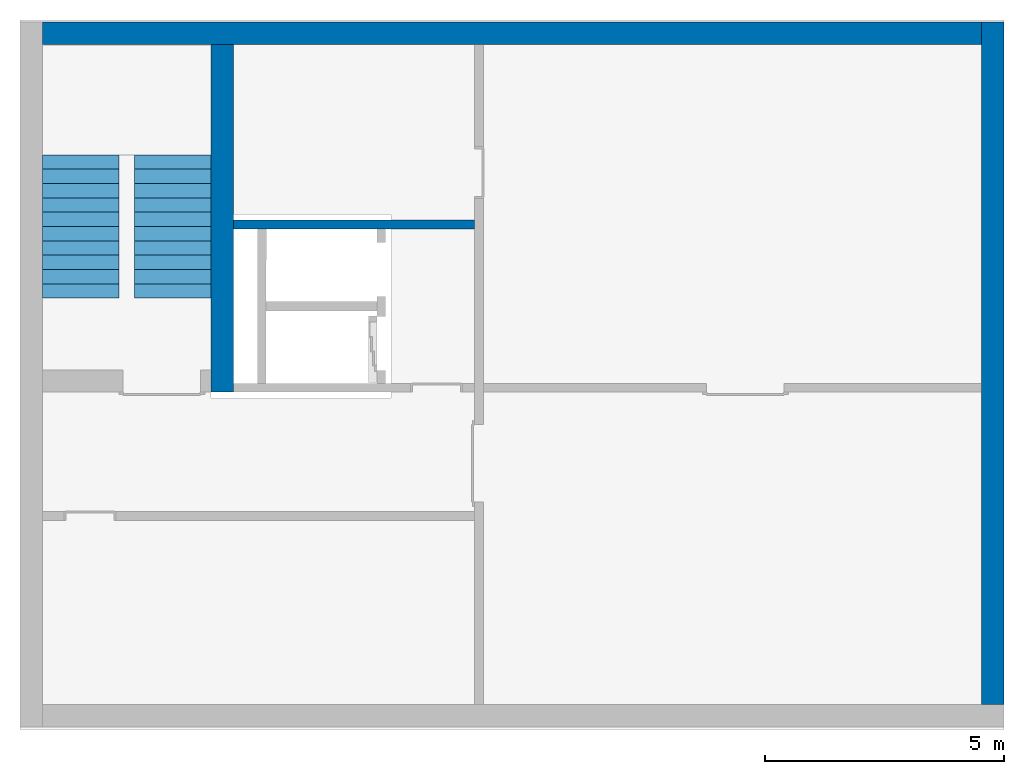
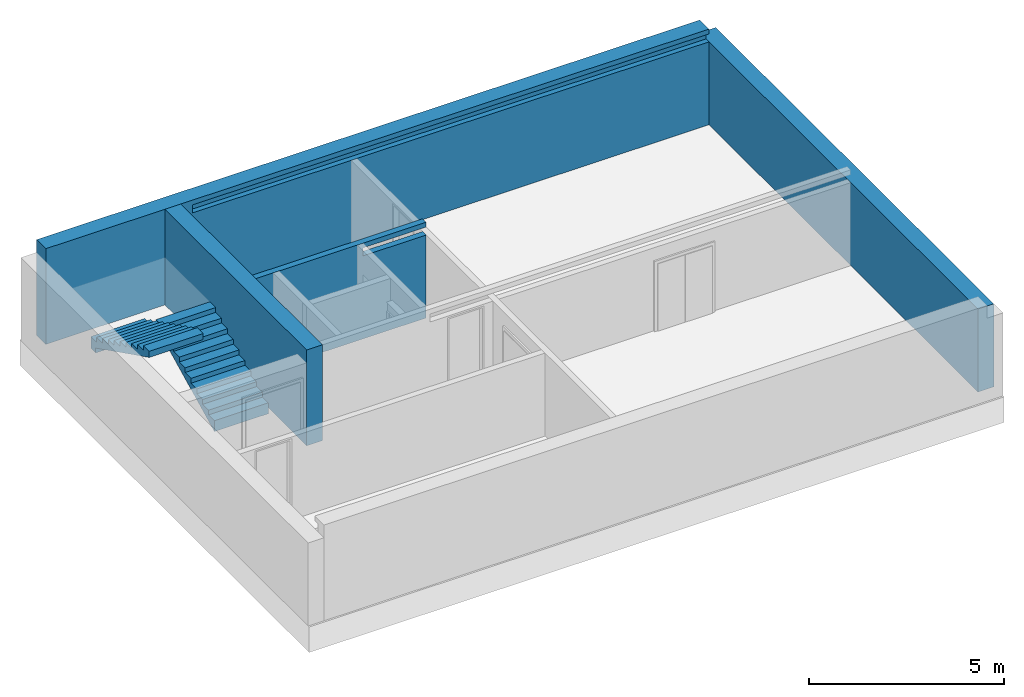
# One storey, part 2 of 3: 4 walls, 2 building element parts, 2 elements without a shape of their own.
"""IFC4 building model written with IfcOpenShell, lengths in metres."""

from ifc_helpers import new_model, entity, si_unit, converted_unit, derived_unit, direction, frame, origin_with_axes, place, context, subcontext, project, spatial, polygons, material, type_object, element, aggregate, save


model = new_model("IFC4")

# Units and contexts
model_context = context("Model", 3, precision=1e-05, world=origin_with_axes(), true_north=direction((0.0, 1.0)))
body_context = subcontext(model_context, "Body", "Model", "MODEL_VIEW")
ifc_project = project(units=[si_unit("LENGTHUNIT", "METRE"), si_unit("AREAUNIT", "SQUARE_METRE"), si_unit("VOLUMEUNIT", "CUBIC_METRE"), converted_unit("PLANEANGLEUNIT", "DEGREE", entity("IfcPlaneAngleMeasure", 0.0174532925199433), si_unit("PLANEANGLEUNIT", "RADIAN"), dimensions=[0, 0, 0, 0, 0, 0, 0]), converted_unit("TIMEUNIT", "Year", entity("IfcTimeMeasure", 31557600.0), si_unit("TIMEUNIT", "SECOND"), dimensions=[0, 0, 1, 0, 0, 0, 0]), si_unit("MASSUNIT", "GRAM", prefix="KILO"), si_unit("THERMODYNAMICTEMPERATUREUNIT", "DEGREE_CELSIUS"), si_unit("LUMINOUSINTENSITYUNIT", "LUMEN"), si_unit("ENERGYUNIT", "JOULE", prefix="MEGA"), derived_unit("THERMALCONDUCTANCEUNIT", [(si_unit("POWERUNIT", "WATT"), 1), (si_unit("LENGTHUNIT", "METRE"), -1), (si_unit("THERMODYNAMICTEMPERATUREUNIT", "KELVIN"), -1)]), derived_unit("SPECIFICHEATCAPACITYUNIT", [(si_unit("ENERGYUNIT", "JOULE"), 1), (si_unit("MASSUNIT", "GRAM", prefix="KILO"), -1), (si_unit("THERMODYNAMICTEMPERATUREUNIT", "KELVIN"), -1)]), derived_unit("MASSDENSITYUNIT", [(si_unit("MASSUNIT", "GRAM", prefix="KILO"), 1), (si_unit("VOLUMEUNIT", "CUBIC_METRE"), -1)])], contexts=[model_context])

# Site, building, storey
site_placement = place(None, origin_with_axes())
site = spatial("IfcSite", under=ifc_project, at=site_placement, CompositionType="ELEMENT")
building_placement = place(site_placement, origin_with_axes())
building = spatial("IfcBuilding", under=site, at=building_placement, CompositionType="ELEMENT")
storey_placement = place(building_placement, frame((0.0, 0.0, -3.0), z_axis=(0.0, 0.0, 1.0), x_axis=(1.0, 0.0, 0.0)))
storey = spatial("IfcBuildingStorey", under=building, at=storey_placement, Name="UG", CompositionType="ELEMENT", Elevation=-3.0)

# Walls
ifc_material_1 = material(Name="Stahlbeton")
wall_type_1 = type_object("IfcWallType", Name="Stahlbeton 470", PredefinedType="NOTDEFINED")
wall_1_placement = place(storey_placement, frame((27.988, 14.3318657372406, 0.0), z_axis=(0.0, 0.0, 1.0), x_axis=(0.0, -1.0, 0.0)))
element("IfcWall", 1, at=wall_1_placement, inside=storey, type_object=wall_type_1, material=ifc_material_1, Name="Wand-003", PredefinedType="NOTDEFINED", context=body_context, shape_type="Tessellation", body=[
    polygons([(7.276865791773, 0.469999999999999, 3.0), (7.276865791773, 0.0, 3.0), (7.27686579177299, 0.0, 2.6), (7.27686579177299, 0.469999999999999, 2.6), (0.0, 0.469999999999999, 3.0), (0.0, 0.0, 3.0), (0.0, 0.0, 0.0), (7.27686579177299, 0.0, 0.0), (7.27686579177299, 0.469999999999999, 0.0), (0.0, 0.469999999999999, 0.0)], [[[1, 2, 3, 4]], [[5, 6, 2, 1]], [[6, 7, 8, 3, 2]], [[3, 8, 9, 4]], [[5, 1, 4, 9, 10]], [[6, 5, 10, 7]], [[7, 10, 9, 8]]], closed=True),
])
wall_2_placement = place(storey_placement, frame((44.114, 14.3318657372406, 0.0), z_axis=(0.0, 0.0, 1.0), x_axis=(-1.0, 0.0, 0.0)))
element("IfcWall", 2, at=wall_2_placement, inside=storey, type_object=wall_type_1, material=ifc_material_1, Name="Wand-004", PredefinedType="NOTDEFINED", context=body_context, shape_type="Tessellation", body=[
    polygons([(0.0, 0.0, 2.85), (0.0, -0.151134016234401, 2.85), (0.0, -0.151134016234401, 2.6), (0.0, -0.470000000000001, 2.6), (0.0, -0.470000000000001, 3.0), (0.0, 0.0, 3.0), (15.306, -0.151134016234401, 2.85), (15.306, 0.0, 2.85), (15.306, -0.151134016234401, 2.6), (0.0, 0.0, 2.6), (0.0, 0.0, 0.0), (0.0, -0.470000000000001, 0.0), (19.656, -0.470000000000002, 3.0), (19.656, -0.470000000000001, 0.0), (19.656, -0.470000000000001, 2.6), (19.656, -0.470000000000002, 2.85), (19.656, 0.0, 3.0), (15.306, 0.0, 2.6), (19.656, 0.0, 2.85), (19.656, 0.0, 2.6), (19.656, 0.0, 0.0)], [[[1, 2, 3, 4, 5, 6]], [[7, 2, 1, 8]], [[9, 3, 2, 7]], [[4, 3, 10, 11, 12]], [[13, 5, 4, 12, 14, 15, 16]], [[6, 5, 13, 17]], [[18, 8, 1, 6, 17, 19, 20, 21, 11, 10]], [[7, 8, 18, 9]], [[18, 10, 3, 9]], [[21, 14, 12, 11]], [[14, 21, 20, 15]], [[19, 16, 15, 20]], [[16, 19, 17, 13]]], closed=True),
])
wall_3_placement = place(storey_placement, frame((44.114, 0.52, 0.0), z_axis=(0.0, 0.0, 1.0), x_axis=(0.0, 1.0, 0.0)))
element("IfcWall", 3, at=wall_3_placement, inside=storey, type_object=wall_type_1, material=ifc_material_1, Name="Wand-003", PredefinedType="NOTDEFINED", context=body_context, shape_type="Tessellation", body=[
    polygons([(14.2818657372405, -0.469999999999999, 2.6), (14.2818657372405, 0.0, 2.6), (0.0, 0.0, 2.6), (0.0, -0.469999999999999, 2.6), (14.2818657372405, -0.469999999999999, 0.0), (14.2818657372405, 0.0, 0.0), (0.0, 0.0, 0.0), (0.0, -0.469999999999999, 0.0)], [[[1, 2, 3, 4]], [[2, 1, 5, 6]], [[2, 6, 7, 3]], [[8, 4, 3, 7]], [[5, 1, 4, 8]], [[6, 5, 8, 7]]], closed=True),
])
wall_type_2 = type_object("IfcWallType", Name="Stahlbeton 180", PredefinedType="NOTDEFINED")
wall_4_placement = place(storey_placement, frame((33.505, 10.6549999454676, 0.0), z_axis=(0.0, 0.0, 1.0), x_axis=(-1.0, 0.0, 0.0)))
element("IfcWall", 4, at=wall_4_placement, inside=storey, type_object=wall_type_2, material=ifc_material_1, Name="Wand-003", PredefinedType="NOTDEFINED", context=body_context, shape_type="Tessellation", body=[
    polygons([(0.0, 0.18, 3.0), (0.0, 0.180000000000001, 2.85), (0.0, 0.0, 2.85), (0.0, 0.0, 3.0), (1.8669999709129, 0.18, 2.6), (1.8669999709129, 0.18, 2.85), (5.04699999999999, 0.18, 3.0), (5.04699999999999, 0.18, 0.0), (0.0, 0.18, 0.0), (0.0, 0.180000000000003, 2.6), (1.8669999709129, -8.86263311627999e-08, 2.85), (1.8669999709129, -8.86263311627999e-08, 2.6), (0.0, 0.0, 2.6), (0.0, 0.0, 0.0), (5.04699999999999, 0.0, 0.0), (5.04699999999999, 0.0, 3.0)], [[[1, 2, 3, 4]], [[5, 6, 2, 1, 7, 8, 9, 10]], [[6, 11, 3, 2]], [[11, 12, 13, 14, 15, 16, 4, 3]], [[4, 16, 7, 1]], [[5, 12, 11, 6]], [[8, 7, 16, 15]], [[8, 15, 14, 9]], [[14, 13, 10, 9]], [[5, 10, 13, 12]]], closed=True),
])

# Stair, building element part
stair_type = type_object("IfcStairType", PredefinedType="NOTDEFINED")
stair_1_placement = place(storey_placement, frame((26.388, 9.02499994546755, 0.0), z_axis=(0.0, 0.0, 1.0), x_axis=(1.0, 0.0, 0.0)))
stair_1 = element("IfcStair", 5, at=stair_1_placement, inside=storey, type_object=stair_type, Name="Treppe - 003", PredefinedType="NOTDEFINED")
ifc_material_2 = material(Name="Stahlbeton Decke")
building_element_part_1_placement = place(stair_1_placement, origin_with_axes())
building_element_part_1 = element("IfcBuildingElementPart", 6, at=building_element_part_1_placement, material=ifc_material_2, Name="Stahlbeton Decke", PredefinedType="NOTDEFINED", context=body_context, shape_type="Tessellation", body=[
    polygons([(1.6, 2.775, 1.19743422191252), (1.6, 2.85, 1.23493422191252), (1.6, 2.925, 1.27243422191252), (1.6, 3.0, 1.30993422191252), (1.6, 3.0, 1.5), (1.6, 2.7, 1.5), (1.6, 2.7, 1.35), (1.6, 2.4, 1.35), (1.6, 2.4, 1.2), (1.6, 2.1, 1.2), (1.6, 2.1, 1.05), (1.6, 1.8, 1.05), (1.6, 1.8, 0.9), (1.6, 1.5, 0.9), (1.6, 1.5, 0.75), (1.6, 1.2, 0.75), (1.6, 1.2, 0.6), (1.6, 0.899999999999999, 0.6), (1.6, 0.899999999999999, 0.45), (1.6, 0.6, 0.45), (1.6, 0.6, 0.3), (1.6, 0.3, 0.3), (1.6, 0.3, 0.15), (1.6, 0.0, 0.15), (1.6, 0.0, -0.190065778087482), (1.6, 0.0999999999999999, -0.140065778087482), (1.6, 0.2, -0.0900657780874821), (1.6, 0.3, -0.0400657780874822), (1.6, 0.4, 0.0099342219125178), (1.6, 0.5, 0.0599342219125178), (1.6, 0.6, 0.109934221912518), (1.6, 0.7, 0.159934221912518), (1.6, 0.8, 0.209934221912518), (1.6, 0.899999999999999, 0.259934221912518), (1.6, 0.975, 0.297434221912518), (1.6, 1.05, 0.334934221912518), (1.6, 1.125, 0.372434221912518), (1.6, 1.2, 0.409934221912518), (1.6, 1.275, 0.447434221912518), (1.6, 1.35, 0.484934221912518), (1.6, 1.425, 0.522434221912518), (1.6, 1.5, 0.559934221912518), (1.6, 1.575, 0.597434221912518), (1.6, 1.65, 0.634934221912518), (1.6, 1.725, 0.672434221912518), (1.6, 1.8, 0.709934221912518), (1.6, 1.9, 0.759934221912518), (1.6, 2.0, 0.809934221912518), (1.6, 2.1, 0.859934221912518), (1.6, 2.2, 0.909934221912518), (1.6, 2.3, 0.959934221912518), (1.6, 2.4, 1.00993422191252), (1.6, 2.5, 1.05993422191252), (1.6, 2.6, 1.10993422191252), (1.6, 2.7, 1.15993422191252), (0.0, 2.775, 1.19743422191252), (0.0, 2.85, 1.23493422191252), (0.0, 2.925, 1.27243422191252), (0.0, 3.0, 1.30993422191252), (0.0, 3.0, 1.5), (0.0, 2.7, 1.5), (0.0, 2.7, 1.35), (0.0, 2.4, 1.35), (0.0, 2.4, 1.2), (0.0, 2.1, 1.2), (0.0, 2.1, 1.05), (0.0, 1.8, 1.05), (0.0, 1.8, 0.9), (0.0, 1.5, 0.9), (0.0, 1.5, 0.75), (0.0, 1.2, 0.75), (0.0, 1.2, 0.6), (0.0, 0.899999999999999, 0.6), (0.0, 0.899999999999999, 0.45), (0.0, 0.6, 0.45), (0.0, 0.6, 0.3), (0.0, 0.3, 0.3), (0.0, 0.3, 0.15), (0.0, 0.0, 0.15), (0.0, 0.0, -0.190065778087482), (0.0, 0.0999999999999999, -0.140065778087482), (0.0, 0.2, -0.0900657780874821), (0.0, 0.3, -0.0400657780874822), (0.0, 0.4, 0.0099342219125178), (0.0, 0.5, 0.0599342219125178), (0.0, 0.6, 0.109934221912518), (0.0, 0.7, 0.159934221912518), (0.0, 0.8, 0.209934221912518), (0.0, 0.899999999999999, 0.259934221912518), (0.0, 0.975, 0.297434221912518), (0.0, 1.05, 0.334934221912518), (0.0, 1.125, 0.372434221912518), (0.0, 1.2, 0.409934221912518), (0.0, 1.275, 0.447434221912518), (0.0, 1.35, 0.484934221912518), (0.0, 1.425, 0.522434221912518), (0.0, 1.5, 0.559934221912518), (0.0, 1.575, 0.597434221912518), (0.0, 1.65, 0.634934221912518), (0.0, 1.725, 0.672434221912518), (0.0, 1.8, 0.709934221912518), (0.0, 1.9, 0.759934221912518), (0.0, 2.0, 0.809934221912518), (0.0, 2.1, 0.859934221912518), (0.0, 2.2, 0.909934221912518), (0.0, 2.3, 0.959934221912518), (0.0, 2.4, 1.00993422191252), (0.0, 2.5, 1.05993422191252), (0.0, 2.6, 1.10993422191252), (0.0, 2.7, 1.15993422191252)], [[[1, 2, 3, 4, 5, 6, 7, 8, 9, 10, 11, 12, 13, 14, 15, 16, 17, 18, 19, 20, 21, 22, 23, 24, 25, 26, 27, 28, 29, 30, 31, 32, 33, 34, 35, 36, 37, 38, 39, 40, 41, 42, 43, 44, 45, 46, 47, 48, 49, 50, 51, 52, 53, 54, 55]], [[56, 57, 2, 1]], [[57, 58, 3, 2]], [[58, 59, 4, 3]], [[5, 4, 59, 60]], [[5, 60, 61, 6]], [[61, 62, 7, 6]], [[62, 63, 8, 7]], [[9, 8, 63, 64]], [[64, 65, 10, 9]], [[11, 10, 65, 66]], [[66, 67, 12, 11]], [[13, 12, 67, 68]], [[68, 69, 14, 13]], [[15, 14, 69, 70]], [[70, 71, 16, 15]], [[17, 16, 71, 72]], [[72, 73, 18, 17]], [[19, 18, 73, 74]], [[74, 75, 20, 19]], [[21, 20, 75, 76]], [[76, 77, 22, 21]], [[23, 22, 77, 78]], [[78, 79, 24, 23]], [[24, 79, 80, 25]], [[80, 81, 26, 25]], [[81, 82, 27, 26]], [[82, 83, 28, 27]], [[83, 84, 29, 28]], [[84, 85, 30, 29]], [[85, 86, 31, 30]], [[86, 87, 32, 31]], [[87, 88, 33, 32]], [[88, 89, 34, 33]], [[89, 90, 35, 34]], [[90, 91, 36, 35]], [[91, 92, 37, 36]], [[92, 93, 38, 37]], [[93, 94, 39, 38]], [[94, 95, 40, 39]], [[95, 96, 41, 40]], [[96, 97, 42, 41]], [[97, 98, 43, 42]], [[98, 99, 44, 43]], [[99, 100, 45, 44]], [[100, 101, 46, 45]], [[101, 102, 47, 46]], [[102, 103, 48, 47]], [[103, 104, 49, 48]], [[104, 105, 50, 49]], [[105, 106, 51, 50]], [[106, 107, 52, 51]], [[107, 108, 53, 52]], [[108, 109, 54, 53]], [[109, 110, 55, 54]], [[110, 56, 1, 55]], [[83, 82, 81, 80, 79, 78, 77, 76, 75, 74, 73, 72, 71, 70, 69, 68, 67, 66, 65, 64, 63, 62, 61, 60, 59, 58, 57, 56, 110, 109, 108, 107, 106, 105, 104, 103, 102, 101, 100, 99, 98, 97, 96, 95, 94, 93, 92, 91, 90, 89, 88, 87, 86, 85, 84]]], closed=True),
])
aggregate(stair_1, [building_element_part_1])

stair_2_placement = place(storey_placement, frame((24.458, 12.0249999454676, 1.5), z_axis=(0.0, 0.0, 1.0), x_axis=(1.0, 0.0, 0.0)))
stair_2 = element("IfcStair", 7, at=stair_2_placement, inside=storey, type_object=stair_type, Name="Treppe - 003", PredefinedType="NOTDEFINED")
building_element_part_2_placement = place(stair_2_placement, origin_with_axes())
building_element_part_2 = element("IfcBuildingElementPart", 8, at=building_element_part_2_placement, material=ifc_material_2, Name="Stahlbeton Decke", PredefinedType="NOTDEFINED", context=body_context, shape_type="Tessellation", body=[
    polygons([(1.6, 0.0, 0.15), (1.6, 0.0, -0.190065778087482), (0.0, 0.0, -0.190065778087482), (0.0, 0.0, 0.15), (1.6, 0.0, -0.22), (1.6, -0.299999999999999, 0.15), (1.6, -0.299999999999999, 0.3), (1.6, -0.6, 0.3), (1.6, -0.6, 0.45), (1.6, -0.899999999999999, 0.45), (1.6, -0.899999999999999, 0.6), (1.6, -1.2, 0.6), (1.6, -1.2, 0.75), (1.6, -1.5, 0.75), (1.6, -1.5, 0.9), (1.6, -1.8, 0.9), (1.6, -1.8, 1.05), (1.6, -2.1, 1.05), (1.6, -2.1, 1.2), (1.6, -2.4, 1.2), (1.6, -2.4, 1.35), (1.6, -2.7, 1.35), (1.6, -2.7, 1.5), (1.6, -3.0, 1.5), (1.6, -3.0, 1.30993422191252), (1.6, -2.925, 1.27243422191252), (1.6, -2.85, 1.23493422191252), (1.6, -2.775, 1.19743422191252), (1.6, -2.7, 1.15993422191252), (1.6, -2.6, 1.10993422191252), (1.6, -2.5, 1.05993422191252), (1.6, -2.4, 1.00993422191252), (1.6, -2.3, 0.959934221912518), (1.6, -2.2, 0.909934221912518), (1.6, -2.1, 0.859934221912518), (1.6, -2.0, 0.809934221912518), (1.6, -1.9, 0.759934221912518), (1.6, -1.8, 0.709934221912518), (1.6, -1.725, 0.672434221912518), (1.6, -1.65, 0.634934221912518), (1.6, -1.575, 0.597434221912518), (1.6, -1.5, 0.559934221912518), (1.6, -1.425, 0.522434221912518), (1.6, -1.35, 0.484934221912518), (1.6, -1.275, 0.447434221912518), (1.6, -1.2, 0.409934221912518), (1.6, -1.125, 0.372434221912518), (1.6, -1.05, 0.334934221912518), (1.6, -0.975, 0.297434221912518), (1.6, -0.899999999999999, 0.259934221912518), (1.6, -0.799999999999999, 0.209934221912518), (1.6, -0.699999999999999, 0.159934221912518), (1.6, -0.6, 0.109934221912518), (1.6, -0.5, 0.0599342219125178), (1.6, -0.4, 0.0099342219125178), (1.6, -0.299999999999999, -0.0400657780874822), (1.6, -0.25, -0.0650657780874822), (1.6, -0.25, -0.22), (0.0, 0.0, -0.22), (0.0, -0.25, -0.22), (0.0, -0.25, -0.0650657780874822), (0.0, -0.299999999999999, -0.0400657780874822), (0.0, -0.4, 0.0099342219125178), (0.0, -0.5, 0.0599342219125178), (0.0, -0.6, 0.109934221912518), (0.0, -0.699999999999999, 0.159934221912518), (0.0, -0.799999999999999, 0.209934221912518), (0.0, -0.899999999999999, 0.259934221912518), (0.0, -0.975, 0.297434221912518), (0.0, -1.05, 0.334934221912518), (0.0, -1.125, 0.372434221912518), (0.0, -1.2, 0.409934221912518), (0.0, -1.275, 0.447434221912518), (0.0, -1.35, 0.484934221912518), (0.0, -1.425, 0.522434221912518), (0.0, -1.5, 0.559934221912518), (0.0, -1.575, 0.597434221912518), (0.0, -1.65, 0.634934221912518), (0.0, -1.725, 0.672434221912518), (0.0, -1.8, 0.709934221912518), (0.0, -1.9, 0.759934221912518), (0.0, -2.0, 0.809934221912518), (0.0, -2.1, 0.859934221912518), (0.0, -2.2, 0.909934221912518), (0.0, -2.3, 0.959934221912518), (0.0, -2.4, 1.00993422191252), (0.0, -2.5, 1.05993422191252), (0.0, -2.6, 1.10993422191252), (0.0, -2.7, 1.15993422191252), (0.0, -2.775, 1.19743422191252), (0.0, -2.85, 1.23493422191252), (0.0, -2.925, 1.27243422191252), (0.0, -3.0, 1.30993422191252), (0.0, -3.0, 1.5), (0.0, -2.7, 1.5), (0.0, -2.7, 1.35), (0.0, -2.4, 1.35), (0.0, -2.4, 1.2), (0.0, -2.1, 1.2), (0.0, -2.1, 1.05), (0.0, -1.8, 1.05), (0.0, -1.8, 0.9), (0.0, -1.5, 0.9), (0.0, -1.5, 0.75), (0.0, -1.2, 0.75), (0.0, -1.2, 0.6), (0.0, -0.899999999999999, 0.6), (0.0, -0.899999999999999, 0.45), (0.0, -0.6, 0.45), (0.0, -0.6, 0.3), (0.0, -0.299999999999999, 0.3), (0.0, -0.299999999999999, 0.15)], [[[1, 2, 3, 4]], [[5, 2, 1, 6, 7, 8, 9, 10, 11, 12, 13, 14, 15, 16, 17, 18, 19, 20, 21, 22, 23, 24, 25, 26, 27, 28, 29, 30, 31, 32, 33, 34, 35, 36, 37, 38, 39, 40, 41, 42, 43, 44, 45, 46, 47, 48, 49, 50, 51, 52, 53, 54, 55, 56, 57, 58]], [[59, 3, 2, 5]], [[60, 61, 62, 63, 64, 65, 66, 67, 68, 69, 70, 71, 72, 73, 74, 75, 76, 77, 78, 79, 80, 81, 82, 83, 84, 85, 86, 87, 88, 89, 90, 91, 92, 93, 94, 95, 96, 97, 98, 99, 100, 101, 102, 103, 104, 105, 106, 107, 108, 109, 110, 111, 112, 4, 3, 59]], [[6, 1, 4, 112]], [[112, 111, 7, 6]], [[8, 7, 111, 110]], [[110, 109, 9, 8]], [[10, 9, 109, 108]], [[108, 107, 11, 10]], [[12, 11, 107, 106]], [[106, 105, 13, 12]], [[14, 13, 105, 104]], [[104, 103, 15, 14]], [[16, 15, 103, 102]], [[102, 101, 17, 16]], [[18, 17, 101, 100]], [[100, 99, 19, 18]], [[20, 19, 99, 98]], [[98, 97, 21, 20]], [[22, 21, 97, 96]], [[96, 95, 23, 22]], [[95, 94, 24, 23]], [[24, 94, 93, 25]], [[26, 25, 93, 92]], [[27, 26, 92, 91]], [[28, 27, 91, 90]], [[29, 28, 90, 89]], [[30, 29, 89, 88]], [[31, 30, 88, 87]], [[32, 31, 87, 86]], [[33, 32, 86, 85]], [[34, 33, 85, 84]], [[35, 34, 84, 83]], [[36, 35, 83, 82]], [[37, 36, 82, 81]], [[38, 37, 81, 80]], [[39, 38, 80, 79]], [[40, 39, 79, 78]], [[41, 40, 78, 77]], [[42, 41, 77, 76]], [[43, 42, 76, 75]], [[44, 43, 75, 74]], [[45, 44, 74, 73]], [[46, 45, 73, 72]], [[47, 46, 72, 71]], [[48, 47, 71, 70]], [[49, 48, 70, 69]], [[50, 49, 69, 68]], [[51, 50, 68, 67]], [[52, 51, 67, 66]], [[53, 52, 66, 65]], [[54, 53, 65, 64]], [[55, 54, 64, 63]], [[56, 55, 63, 62]], [[62, 61, 57, 56]], [[58, 57, 61, 60]], [[58, 60, 59, 5]]], closed=True),
])
aggregate(stair_2, [building_element_part_2])

save(model, "model.ifc")
